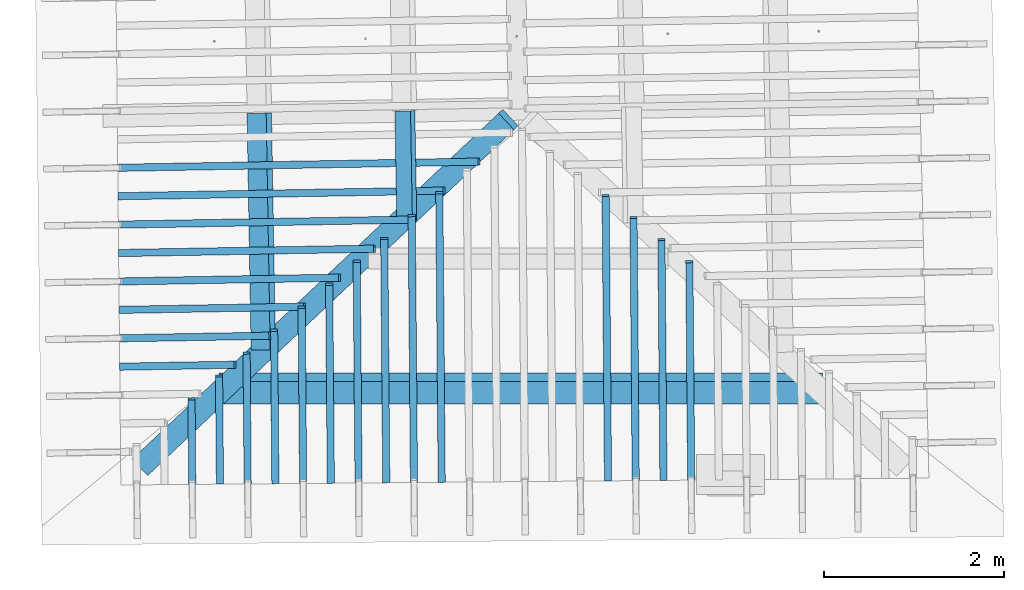
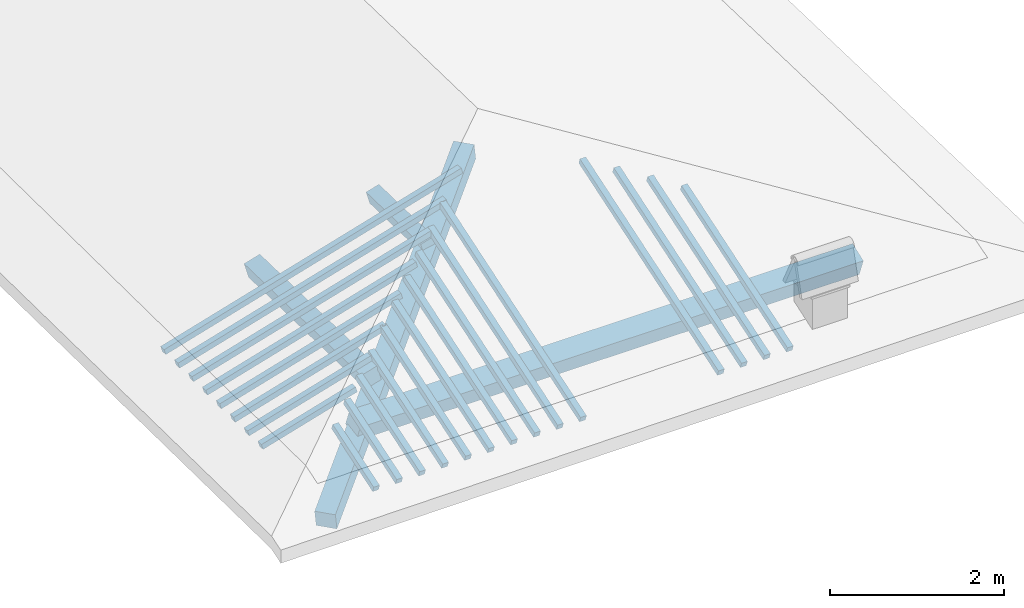
# One storey, part 1 of 19: 23 beams, 3 members, 2 elements without a shape of their own.
"""IFC4 building model written with IfcOpenShell, lengths in metres."""

from ifc_helpers import new_model, entity, si_unit, converted_unit, derived_unit, direction, frame, origin, place, context, subcontext, project, spatial, indexed_curve, outline, extrude, source, transform, mapped, material, type_object, type_shapes, element, aggregate, save


model = new_model("IFC4")

# Units and contexts
model_context = context("Model", 3, precision=1e-05, world=origin(), true_north=direction((6.123233995736766e-17, 1.0)))
body_context = subcontext(model_context, "Body", "Model", "MODEL_VIEW")
ifc_project = project(units=[si_unit("LENGTHUNIT", "METRE"), si_unit("AREAUNIT", "SQUARE_METRE"), si_unit("VOLUMEUNIT", "CUBIC_METRE"), converted_unit("PLANEANGLEUNIT", "DEGREE", entity("IfcPlaneAngleMeasure", 0.017453292519943278), si_unit("PLANEANGLEUNIT", "RADIAN"), dimensions=[0, 0, 0, 0, 0, 0, 0]), derived_unit("THERMALTRANSMITTANCEUNIT", [(si_unit("MASSUNIT", "GRAM", prefix="KILO"), 1), (si_unit("THERMODYNAMICTEMPERATUREUNIT", "KELVIN"), -1), (si_unit("TIMEUNIT", "SECOND"), -3)])], contexts=[model_context])

# Site, building, storey
site_placement = place(None, origin())
site = spatial("IfcSite", under=ifc_project, at=site_placement, CompositionType="ELEMENT")
building_placement = place(site_placement, origin())
building = spatial("IfcBuilding", under=site, at=building_placement, CompositionType="ELEMENT")
storey_placement = place(building_placement, frame((0.0, 0.0, 3.28)))
storey = spatial("IfcBuildingStorey", under=building, at=storey_placement, Name="Livello Copertura", CompositionType="ELEMENT", Elevation=3.28)

# Beam
ifc_material = material(Name="Legno - Legno da costruzione", Category="Legno")
beam_type_1 = type_object("IfcBeamType", Name="Legno:250x250", PredefinedType="BEAM", material=ifc_material)
shared_shape_1 = source(origin(), body_context, "Body", "SweptSolid", [
    extrude(outline(indexed_curve([(-2.8865, -0.12500000000000164), (2.8865, -0.12500000000000164), (2.8865, 0.12500000000000164), (-2.8865, 0.12500000000000164), (-2.8865, -0.12500000000000164)], self_intersect=False)), frame((-0.09300000000000051, 0.0, -0.1250000000000054), z_axis=(0.0, 0.0, 1.0), x_axis=(-1.0, 0.0, 0.0)), (0.0, 0.0, 1.0), 0.2499999999999999),
])
type_shapes(beam_type_1, [shared_shape_1])
beam_1_placement = place(storey_placement, frame((-2.1819750349168454, -1.0245673209281938, 0.3635737384132199), z_axis=(-0.1841295453761407, -0.1738218141454754, 0.967410092694278), x_axis=(0.7034691955432926, 0.6640883814436331, 0.2532147557968305)))
element("IfcBeam", 1, at=beam_1_placement, inside=storey, type_object=beam_type_1, material=ifc_material, Name="Legno:250x250", ObjectType="Legno:250x250", PredefinedType="BEAM", context=body_context, shape_type="MappedRepresentation", body=[
    mapped(shared_shape_1, transform((0.0, 0.0, 0.0), scale=1.0)),
])

# Members
member_type_1 = type_object("IfcMemberType", Name="Legno:220x220", PredefinedType="PURLIN", material=ifc_material)
shared_shape_2 = source(origin(), body_context, "Body", "SweptSolid", [
    extrude(outline(indexed_curve([(-0.11000000000000108, -0.11000000000000044), (0.11000000000000193, -0.11000000000000029), (0.110000000000002, 0.10999999999999963), (-0.11000000000000106, 0.10999999999999947), (-0.11000000000000108, -0.11000000000000044)], self_intersect=False)), frame((-2.9781171366202996, 0.89954546921723, 3.646958206215557), z_axis=(0.01708489701561066, -0.9998540424951864, 0.0), x_axis=(-0.9630219859926785, -0.016455533263029242, -0.2689198206152659)), (0.0, 0.0, 1.0), 2.6226681228820965),
])
type_shapes(member_type_1, [shared_shape_2])
member_1_placement = place(storey_placement, frame((0.0, 0.0, -3.28)))
element("IfcMember", 2, at=member_1_placement, inside=storey, type_object=member_type_1, material=ifc_material, Name="Legno:220x220", ObjectType="Legno:220x220", PredefinedType="PURLIN", context=body_context, shape_type="MappedRepresentation", body=[
    mapped(shared_shape_2, transform((0.0, 0.0, 0.0), scale=1.0)),
])
member_type_2 = type_object("IfcMemberType", Name="Legno:265x265", PredefinedType="PURLIN", material=ifc_material)
shared_shape_3 = source(origin(), body_context, "Body", "SweptSolid", [
    extrude(outline(indexed_curve([(-3.3463770603795675, -0.13250000000000164), (3.3463770603795675, -0.13250000000000164), (3.3463770603795675, 0.13250000000000164), (-3.3463770603795675, 0.13250000000000164), (-3.3463770603795675, -0.13250000000000164)], self_intersect=False)), frame((0.018176232400256256, 0.0, -0.13250000000000545), z_axis=(0.0, 0.0, 1.0), x_axis=(-1.0, 0.0, 0.0)), (0.0, 0.0, 1.0), 0.2649999999999999),
])
type_shapes(member_type_2, [shared_shape_3])
member_2_placement = place(storey_placement, frame((-0.0971509312741571, -2.151959629485876, 0.12418479170253889), z_axis=(0.0, -0.3542910379977155, 0.9351352096860119), x_axis=(1.0, 0.0, 0.0)))
element("IfcMember", 3, at=member_2_placement, inside=storey, type_object=member_type_2, material=ifc_material, Name="Legno:265x265", ObjectType="Legno:265x265", PredefinedType="PURLIN", context=body_context, shape_type="MappedRepresentation", body=[
    mapped(shared_shape_3, transform((0.0, 0.0, 0.0), scale=1.0)),
])
member_type_3 = type_object("IfcMemberType", Name="Legno:180x180", PredefinedType="PURLIN", material=ifc_material)
shared_shape_4 = source(origin(), body_context, "Body", "SweptSolid", [
    extrude(outline(indexed_curve([(-0.09000000000000193, -0.09000000000000048), (0.09000000000000151, -0.09000000000000055), (0.0900000000000019, 0.08999999999999937), (-0.09000000000000154, 0.08999999999999944), (-0.09000000000000193, -0.09000000000000048)], self_intersect=False)), frame((-1.3641247132135974, 0.9270290763723007, 4.0767390011549605), z_axis=(0.017084897015610844, -0.9998540424951865, 0.0), x_axis=(-0.9630219859926783, -0.016455533263029284, -0.2689198206152666)), (0.0, 0.0, 1.0), 1.2258736313036205),
])
type_shapes(member_type_3, [shared_shape_4])
member_3_placement = place(storey_placement, frame((0.0, 0.0, -3.28)))
element("IfcMember", 4, at=member_3_placement, inside=storey, type_object=member_type_3, material=ifc_material, Name="Legno:180x180", ObjectType="Legno:180x180", PredefinedType="PURLIN", context=body_context, shape_type="MappedRepresentation", body=[
    mapped(shared_shape_4, transform((0.0, 0.0, 0.0), scale=1.0)),
])

# Assembly, beams
assembly_1_placement = place(storey_placement, origin())
assembly_1 = element("IfcElementAssembly", 5, at=assembly_1_placement, inside=storey, Name="Sistema di travi strutturali:Sistema di travi strutturali", ObjectType="Sistema di travi strutturali:Sistema di travi strutturali", AssemblyPlace="NOTDEFINED", PredefinedType="BEAM_GRID")
beam_type_2 = type_object("IfcBeamType", Name="Legno:80x80", PredefinedType="JOIST", material=ifc_material)
shared_shape_5 = source(origin(), body_context, "Body", "SweptSolid", [
    extrude(outline(indexed_curve([(-2.0725000000000002, -0.04000000000000169), (2.0725000000000002, -0.04000000000000169), (2.0725000000000002, 0.04000000000000169), (-2.0725000000000002, 0.04000000000000169), (-2.0725000000000002, -0.04000000000000169)], self_intersect=False)), frame((0.0, 0.0, -0.040000000000005476), z_axis=(0.0, 0.0, 1.0), x_axis=(-1.0, 0.0, 0.0)), (0.0, 0.0, 1.0), 0.07999999999999997),
])
type_shapes(beam_type_2, [shared_shape_5])
beam_2_placement = place(assembly_1_placement, frame((-2.540443742400321, 0.3301116459614146, 0.6418508556695266), z_axis=(-0.26888056974925345, -0.004594467440668276, 0.9631625667976583), x_axis=(0.9630219859926786, 0.016455533263026963, 0.26891982061526537)))
beam_2 = element("IfcBeam", 6, at=beam_2_placement, type_object=beam_type_2, material=ifc_material, Name="Legno:80x80", ObjectType="Legno:80x80", PredefinedType="JOIST", context=body_context, shape_type="MappedRepresentation", body=[
    mapped(shared_shape_5, transform((0.0, 0.0, 0.0), scale=1.0)),
])
beam_type_3 = type_object("IfcBeamType", Name="Legno:80x80", PredefinedType="JOIST", material=ifc_material)
shared_shape_6 = source(origin(), body_context, "Body", "SweptSolid", [
    extrude(outline(indexed_curve([(-1.8705, -0.04000000000000169), (1.8705, -0.04000000000000169), (1.8705, 0.04000000000000169), (-1.8705, 0.04000000000000169), (-1.8705, -0.04000000000000169)], self_intersect=False)), frame((0.0, 0.0, -0.040000000000005476), z_axis=(0.0, 0.0, 1.0), x_axis=(-1.0, 0.0, 0.0)), (0.0, 0.0, 1.0), 0.07999999999999997),
])
type_shapes(beam_type_3, [shared_shape_6])
beam_3_placement = place(assembly_1_placement, frame((-2.732021318734577, 0.011792101672826176, 0.5868507980634393), z_axis=(-0.2688805697492534, -0.004594467440668275, 0.9631625667976583), x_axis=(0.9630219859926786, 0.01645553326302697, 0.2689198206152653)))
beam_3 = element("IfcBeam", 7, at=beam_3_placement, type_object=beam_type_3, material=ifc_material, Name="Legno:80x80", ObjectType="Legno:80x80", PredefinedType="JOIST", context=body_context, shape_type="MappedRepresentation", body=[
    mapped(shared_shape_6, transform((0.0, 0.0, 0.0), scale=1.0)),
])
beam_type_4 = type_object("IfcBeamType", Name="Legno:80x80", PredefinedType="JOIST", material=ifc_material)
shared_shape_7 = source(origin(), body_context, "Body", "SweptSolid", [
    extrude(outline(indexed_curve([(-1.6685, -0.04000000000000169), (1.6685, -0.04000000000000169), (1.6685, 0.04000000000000169), (-1.6685, 0.04000000000000169), (-1.6685, -0.04000000000000169)], self_intersect=False)), frame((0.0, 0.0, -0.040000000000005476), z_axis=(0.0, 0.0, 1.0), x_axis=(-1.0, 0.0, 0.0)), (0.0, 0.0, 1.0), 0.07999999999999997),
])
type_shapes(beam_type_4, [shared_shape_7])
beam_4_placement = place(assembly_1_placement, frame((-2.9235988950688316, -0.30652744261576, 0.5318507404573531), z_axis=(-0.2688805697492536, -0.004594467440668277, 0.9631625667976583), x_axis=(0.9630219859926786, 0.016455533263026952, 0.26891982061526554)))
beam_4 = element("IfcBeam", 8, at=beam_4_placement, type_object=beam_type_4, material=ifc_material, Name="Legno:80x80", ObjectType="Legno:80x80", PredefinedType="JOIST", context=body_context, shape_type="MappedRepresentation", body=[
    mapped(shared_shape_7, transform((0.0, 0.0, 0.0), scale=1.0)),
])
beam_type_5 = type_object("IfcBeamType", Name="Legno:80x80", PredefinedType="JOIST", material=ifc_material)
shared_shape_8 = source(origin(), body_context, "Body", "SweptSolid", [
    extrude(outline(indexed_curve([(-1.466, -0.04000000000000169), (1.466, -0.04000000000000169), (1.466, 0.04000000000000169), (-1.466, 0.04000000000000169), (-1.466, -0.04000000000000169)], self_intersect=False)), frame((0.0, 0.0, -0.040000000000005476), z_axis=(0.0, 0.0, 1.0), x_axis=(-1.0, 0.0, 0.0)), (0.0, 0.0, 1.0), 0.07999999999999997),
])
type_shapes(beam_type_5, [shared_shape_8])
beam_5_placement = place(assembly_1_placement, frame((-3.1151764714030876, -0.6248469869043484, 0.4768506828512653), z_axis=(-0.2688805697492535, -0.004594467440668277, 0.9631625667976582), x_axis=(0.9630219859926786, 0.016455533263026963, 0.2689198206152654)))
beam_5 = element("IfcBeam", 9, at=beam_5_placement, type_object=beam_type_5, material=ifc_material, Name="Legno:80x80", ObjectType="Legno:80x80", PredefinedType="JOIST", context=body_context, shape_type="MappedRepresentation", body=[
    mapped(shared_shape_8, transform((0.0, 0.0, 0.0), scale=1.0)),
])
beam_type_6 = type_object("IfcBeamType", Name="Legno:80x80", PredefinedType="JOIST", material=ifc_material)
shared_shape_9 = source(origin(), body_context, "Body", "SweptSolid", [
    extrude(outline(indexed_curve([(-1.2640000000000002, -0.04000000000000169), (1.2640000000000002, -0.04000000000000169), (1.2640000000000002, 0.04000000000000169), (-1.2640000000000002, 0.04000000000000169), (-1.2640000000000002, -0.04000000000000169)], self_intersect=False)), frame((0.0, 0.0, -0.040000000000005476), z_axis=(0.0, 0.0, 1.0), x_axis=(-1.0, 0.0, 0.0)), (0.0, 0.0, 1.0), 0.07999999999999997),
])
type_shapes(beam_type_6, [shared_shape_9])
beam_6_placement = place(assembly_1_placement, frame((-3.3067540477373427, -0.9431665311929367, 0.4218506252451776), z_axis=(-0.26888056974925345, -0.004594467440668276, 0.9631625667976582), x_axis=(0.9630219859926786, 0.016455533263026956, 0.26891982061526537)))
beam_6 = element("IfcBeam", 10, at=beam_6_placement, type_object=beam_type_6, material=ifc_material, Name="Legno:80x80", ObjectType="Legno:80x80", PredefinedType="JOIST", context=body_context, shape_type="MappedRepresentation", body=[
    mapped(shared_shape_9, transform((0.0, 0.0, 0.0), scale=1.0)),
])
beam_type_7 = type_object("IfcBeamType", Name="Legno:80x80", PredefinedType="JOIST", material=ifc_material)
shared_shape_10 = source(origin(), body_context, "Body", "SweptSolid", [
    extrude(outline(indexed_curve([(-1.062, -0.04000000000000169), (1.062, -0.04000000000000169), (1.062, 0.04000000000000169), (-1.062, 0.04000000000000169), (-1.062, -0.04000000000000169)], self_intersect=False)), frame((0.0, 0.0, -0.040000000000005476), z_axis=(0.0, 0.0, 1.0), x_axis=(-1.0, 0.0, 0.0)), (0.0, 0.0, 1.0), 0.07999999999999997),
])
type_shapes(beam_type_7, [shared_shape_10])
beam_7_placement = place(assembly_1_placement, frame((-3.4983316240715996, -1.2614860754815251, 0.36685056763908974), z_axis=(-0.2688805697492537, -0.00459446744066828, 0.9631625667976582), x_axis=(0.9630219859926786, 0.016455533263026956, 0.26891982061526565)))
beam_7 = element("IfcBeam", 11, at=beam_7_placement, type_object=beam_type_7, material=ifc_material, Name="Legno:80x80", ObjectType="Legno:80x80", PredefinedType="JOIST", context=body_context, shape_type="MappedRepresentation", body=[
    mapped(shared_shape_10, transform((0.0, 0.0, 0.0), scale=1.0)),
])
beam_type_8 = type_object("IfcBeamType", Name="Legno:80x80", PredefinedType="JOIST", material=ifc_material)
shared_shape_11 = source(origin(), body_context, "Body", "SweptSolid", [
    extrude(outline(indexed_curve([(-0.8595, -0.04000000000000169), (0.8595, -0.04000000000000169), (0.8595, 0.04000000000000169), (-0.8595, 0.04000000000000169), (-0.8595, -0.04000000000000169)], self_intersect=False)), frame((0.0, 0.0, -0.040000000000005476), z_axis=(0.0, 0.0, 1.0), x_axis=(-1.0, 0.0, 0.0)), (0.0, 0.0, 1.0), 0.07999999999999997),
])
type_shapes(beam_type_8, [shared_shape_11])
beam_8_placement = place(assembly_1_placement, frame((-3.6899092004058556, -1.5798056197701134, 0.3118505100330027), z_axis=(-0.2688805697492537, -0.00459446744066828, 0.9631625667976582), x_axis=(0.9630219859926786, 0.01645553326302695, 0.26891982061526565)))
beam_8 = element("IfcBeam", 12, at=beam_8_placement, type_object=beam_type_8, material=ifc_material, Name="Legno:80x80", ObjectType="Legno:80x80", PredefinedType="JOIST", context=body_context, shape_type="MappedRepresentation", body=[
    mapped(shared_shape_11, transform((0.0, 0.0, 0.0), scale=1.0)),
])
beam_type_9 = type_object("IfcBeamType", Name="Legno:80x80", PredefinedType="JOIST", material=ifc_material)
shared_shape_12 = source(origin(), body_context, "Body", "SweptSolid", [
    extrude(outline(indexed_curve([(-0.6575, -0.04000000000000169), (0.6575, -0.04000000000000169), (0.6575, 0.04000000000000169), (-0.6575, 0.04000000000000169), (-0.6575, -0.04000000000000169)], self_intersect=False)), frame((0.0, 0.0, -0.040000000000005476), z_axis=(0.0, 0.0, 1.0), x_axis=(-1.0, 0.0, 0.0)), (0.0, 0.0, 1.0), 0.07999999999999997),
])
type_shapes(beam_type_9, [shared_shape_12])
beam_9_placement = place(assembly_1_placement, frame((-3.8814867767401138, -1.8981251640587042, 0.2568504524269154), z_axis=(-0.2688805697492534, -0.004594467440668276, 0.9631625667976583), x_axis=(0.9630219859926787, 0.016455533263026963, 0.2689198206152653)))
beam_9 = element("IfcBeam", 13, at=beam_9_placement, type_object=beam_type_9, material=ifc_material, Name="Legno:80x80", ObjectType="Legno:80x80", PredefinedType="JOIST", context=body_context, shape_type="MappedRepresentation", body=[
    mapped(shared_shape_12, transform((0.0, 0.0, 0.0), scale=1.0)),
])
aggregate(assembly_1, [beam_2, beam_3, beam_4, beam_5, beam_6, beam_7, beam_8, beam_9])

assembly_2_placement = place(storey_placement, origin())
assembly_2 = element("IfcElementAssembly", 14, at=assembly_2_placement, inside=storey, Name="Sistema di travi strutturali:Sistema di travi strutturali", ObjectType="Sistema di travi strutturali:Sistema di travi strutturali", AssemblyPlace="NOTDEFINED", PredefinedType="BEAM_GRID")
beam_type_10 = type_object("IfcBeamType", Name="Legno:80x80", PredefinedType="JOIST", material=ifc_material)
shared_shape_13 = source(origin(), body_context, "Body", "SweptSolid", [
    extrude(outline(indexed_curve([(-1.2745, -0.04000000000000169), (1.2745, -0.04000000000000169), (1.2745, 0.04000000000000169), (-1.2745, 0.04000000000000169), (-1.2745, -0.04000000000000169)], self_intersect=False)), frame((0.0, 0.0, -0.040000000000005476), z_axis=(0.0, 0.0, 1.0), x_axis=(-1.0, 0.0, 0.0)), (0.0, 0.0, 1.0), 0.07999999999999997),
])
type_shapes(beam_type_10, [shared_shape_13])
beam_10_placement = place(assembly_2_placement, frame((1.799448701656348, -1.9488490470862634, 0.3907229973410812), z_axis=(0.0033933227624359896, -0.3255504700615085, 0.9455185755993168), x_axis=(-0.00793235019477952, 0.9454855083215804, 0.3255675527049189)))
beam_10 = element("IfcBeam", 15, at=beam_10_placement, type_object=beam_type_10, material=ifc_material, Name="Legno:80x80", ObjectType="Legno:80x80", PredefinedType="JOIST", context=body_context, shape_type="MappedRepresentation", body=[
    mapped(shared_shape_13, transform((0.0, 0.0, 0.0), scale=1.0)),
])
beam_type_11 = type_object("IfcBeamType", Name="Legno:80x80", PredefinedType="JOIST", material=ifc_material)
shared_shape_14 = source(origin(), body_context, "Body", "SweptSolid", [
    extrude(outline(indexed_curve([(-1.405, -0.04000000000000169), (1.405, -0.04000000000000169), (1.405, 0.04000000000000169), (-1.405, 0.04000000000000169), (-1.405, -0.04000000000000169)], self_intersect=False)), frame((0.0, 0.0, -0.040000000000005476), z_axis=(0.0, 0.0, 1.0), x_axis=(-1.0, 0.0, 0.0)), (0.0, 0.0, 1.0), 0.07999999999999997),
])
type_shapes(beam_type_11, [shared_shape_14])
beam_11_placement = place(assembly_2_placement, frame((1.4911245811311307, -1.8280614472713421, 0.43341777266915715), z_axis=(0.0033933227624359887, -0.3255504700615087, 0.9455185755993166), x_axis=(-0.007932350194779557, 0.9454855083215804, 0.325567552704919)))
beam_11 = element("IfcBeam", 16, at=beam_11_placement, type_object=beam_type_11, material=ifc_material, Name="Legno:80x80", ObjectType="Legno:80x80", PredefinedType="JOIST", context=body_context, shape_type="MappedRepresentation", body=[
    mapped(shared_shape_14, transform((0.0, 0.0, 0.0), scale=1.0)),
])
beam_type_12 = type_object("IfcBeamType", Name="Legno:80x80", PredefinedType="JOIST", material=ifc_material)
shared_shape_15 = source(origin(), body_context, "Body", "SweptSolid", [
    extrude(outline(indexed_curve([(-1.5355, -0.04000000000000169), (1.5355, -0.04000000000000169), (1.5355, 0.04000000000000169), (-1.5355, 0.04000000000000169), (-1.5355, -0.04000000000000169)], self_intersect=False)), frame((0.0, 0.0, -0.040000000000005476), z_axis=(0.0, 0.0, 1.0), x_axis=(-1.0, 0.0, 0.0)), (0.0, 0.0, 1.0), 0.07999999999999997),
])
type_shapes(beam_type_12, [shared_shape_15])
beam_12_placement = place(assembly_2_placement, frame((1.1828004606059142, -1.7072738474564202, 0.4761125479972341), z_axis=(0.003393322762435989, -0.32555047006150856, 0.9455185755993168), x_axis=(-0.007932350194779537, 0.9454855083215804, 0.32556755270491894)))
beam_12 = element("IfcBeam", 17, at=beam_12_placement, type_object=beam_type_12, material=ifc_material, Name="Legno:80x80", ObjectType="Legno:80x80", PredefinedType="JOIST", context=body_context, shape_type="MappedRepresentation", body=[
    mapped(shared_shape_15, transform((0.0, 0.0, 0.0), scale=1.0)),
])
beam_type_13 = type_object("IfcBeamType", Name="Legno:80x80", PredefinedType="JOIST", material=ifc_material)
shared_shape_16 = source(origin(), body_context, "Body", "SweptSolid", [
    extrude(outline(indexed_curve([(-1.666, -0.04000000000000169), (1.666, -0.04000000000000169), (1.666, 0.04000000000000169), (-1.666, 0.04000000000000169), (-1.666, -0.04000000000000169)], self_intersect=False)), frame((0.0, 0.0, -0.040000000000005476), z_axis=(0.0, 0.0, 1.0), x_axis=(-1.0, 0.0, 0.0)), (0.0, 0.0, 1.0), 0.07999999999999997),
])
type_shapes(beam_type_13, [shared_shape_16])
beam_13_placement = place(assembly_2_placement, frame((0.8744763400806965, -1.5864862476414978, 0.5188073233253101), z_axis=(0.00339332276243599, -0.3255504700615087, 0.9455185755993166), x_axis=(-0.007932350194779563, 0.9454855083215803, 0.32556755270491905)))
beam_13 = element("IfcBeam", 18, at=beam_13_placement, type_object=beam_type_13, material=ifc_material, Name="Legno:80x80", ObjectType="Legno:80x80", PredefinedType="JOIST", context=body_context, shape_type="MappedRepresentation", body=[
    mapped(shared_shape_16, transform((0.0, 0.0, 0.0), scale=1.0)),
])
beam_type_14 = type_object("IfcBeamType", Name="Legno:80x80", PredefinedType="JOIST", material=ifc_material)
shared_shape_17 = source(origin(), body_context, "Body", "SweptSolid", [
    extrude(outline(indexed_curve([(-1.691, -0.04000000000000169), (1.691, -0.04000000000000169), (1.691, 0.04000000000000169), (-1.691, 0.04000000000000169), (-1.691, -0.04000000000000169)], self_intersect=False)), frame((0.0, 0.0, -0.040000000000005476), z_axis=(0.0, 0.0, 1.0), x_axis=(-1.0, 0.0, 0.0)), (0.0, 0.0, 1.0), 0.07999999999999997),
])
type_shapes(beam_type_14, [shared_shape_17])
beam_14_placement = place(assembly_2_placement, frame((-0.9694559132154893, -1.5784086758363005, 0.5282060964588845), z_axis=(0.00339332276243599, -0.3255504700615086, 0.9455185755993168), x_axis=(-0.00793235019477954, 0.9454855083215803, 0.325567552704919)))
beam_14 = element("IfcBeam", 19, at=beam_14_placement, type_object=beam_type_14, material=ifc_material, Name="Legno:80x80", ObjectType="Legno:80x80", PredefinedType="JOIST", context=body_context, shape_type="MappedRepresentation", body=[
    mapped(shared_shape_17, transform((0.0, 0.0, 0.0), scale=1.0)),
])
beam_type_15 = type_object("IfcBeamType", Name="Legno:80x80", PredefinedType="JOIST", material=ifc_material)
shared_shape_18 = source(origin(), body_context, "Body", "SweptSolid", [
    extrude(outline(indexed_curve([(-1.5579999999999998, -0.04000000000000169), (1.5579999999999998, -0.04000000000000169), (1.5579999999999998, 0.04000000000000169), (-1.5579999999999998, 0.04000000000000169), (-1.5579999999999998, -0.04000000000000169)], self_intersect=False)), frame((0.0, 0.0, -0.040000000000005476), z_axis=(0.0, 0.0, 1.0), x_axis=(-1.0, 0.0, 0.0)), (0.0, 0.0, 1.0), 0.07999999999999997),
])
type_shapes(beam_type_15, [shared_shape_18])
beam_15_placement = place(assembly_2_placement, frame((-1.2756894898037632, -1.7068005686503949, 0.4850986496635409), z_axis=(0.0033933227624359896, -0.32555047006150856, 0.9455185755993168), x_axis=(-0.007932350194779546, 0.9454855083215804, 0.32556755270491894)))
beam_15 = element("IfcBeam", 20, at=beam_15_placement, type_object=beam_type_15, material=ifc_material, Name="Legno:80x80", ObjectType="Legno:80x80", PredefinedType="JOIST", context=body_context, shape_type="MappedRepresentation", body=[
    mapped(shared_shape_18, transform((0.0, 0.0, 0.0), scale=1.0)),
])
beam_type_16 = type_object("IfcBeamType", Name="Legno:80x80", PredefinedType="JOIST", material=ifc_material)
shared_shape_19 = source(origin(), body_context, "Body", "SweptSolid", [
    extrude(outline(indexed_curve([(-1.425, -0.04000000000000169), (1.425, -0.04000000000000169), (1.425, 0.04000000000000169), (-1.425, 0.04000000000000169), (-1.425, -0.04000000000000169)], self_intersect=False)), frame((0.0, 0.0, -0.040000000000005476), z_axis=(0.0, 0.0, 1.0), x_axis=(-1.0, 0.0, 0.0)), (0.0, 0.0, 1.0), 0.07999999999999997),
])
type_shapes(beam_type_16, [shared_shape_19])
beam_16_placement = place(assembly_2_placement, frame((-1.5819230663920358, -1.835192461464489, 0.4419912028681974), z_axis=(0.0033933227624359883, -0.3255504700615085, 0.9455185755993168), x_axis=(-0.007932350194779557, 0.9454855083215804, 0.3255675527049189)))
beam_16 = element("IfcBeam", 21, at=beam_16_placement, type_object=beam_type_16, material=ifc_material, Name="Legno:80x80", ObjectType="Legno:80x80", PredefinedType="JOIST", context=body_context, shape_type="MappedRepresentation", body=[
    mapped(shared_shape_19, transform((0.0, 0.0, 0.0), scale=1.0)),
])
beam_type_17 = type_object("IfcBeamType", Name="Legno:80x80", PredefinedType="JOIST", material=ifc_material)
shared_shape_20 = source(origin(), body_context, "Body", "SweptSolid", [
    extrude(outline(indexed_curve([(-1.2925, -0.04000000000000169), (1.2925, -0.04000000000000169), (1.2925, 0.04000000000000169), (-1.2925, 0.04000000000000169), (-1.2925, -0.04000000000000169)], self_intersect=False)), frame((0.0, 0.0, -0.040000000000005476), z_axis=(0.0, 0.0, 1.0), x_axis=(-1.0, 0.0, 0.0)), (0.0, 0.0, 1.0), 0.07999999999999997),
])
type_shapes(beam_type_17, [shared_shape_20])
beam_17_placement = place(assembly_2_placement, frame((-1.8881566429803072, -1.9635843542785834, 0.3988837560728542), z_axis=(0.003393322762435988, -0.3255504700615085, 0.9455185755993168), x_axis=(-0.007932350194779567, 0.9454855083215805, 0.32556755270491883)))
beam_17 = element("IfcBeam", 22, at=beam_17_placement, type_object=beam_type_17, material=ifc_material, Name="Legno:80x80", ObjectType="Legno:80x80", PredefinedType="JOIST", context=body_context, shape_type="MappedRepresentation", body=[
    mapped(shared_shape_20, transform((0.0, 0.0, 0.0), scale=1.0)),
])
beam_type_18 = type_object("IfcBeamType", Name="Legno:80x80", PredefinedType="JOIST", material=ifc_material)
shared_shape_21 = source(origin(), body_context, "Body", "SweptSolid", [
    extrude(outline(indexed_curve([(-1.1595000000000002, -0.04000000000000169), (1.1595000000000002, -0.04000000000000169), (1.1595000000000002, 0.04000000000000169), (-1.1595000000000002, 0.04000000000000169), (-1.1595000000000002, -0.04000000000000169)], self_intersect=False)), frame((0.0, 0.0, -0.040000000000005476), z_axis=(0.0, 0.0, 1.0), x_axis=(-1.0, 0.0, 0.0)), (0.0, 0.0, 1.0), 0.07999999999999997),
])
type_shapes(beam_type_18, [shared_shape_21])
beam_18_placement = place(assembly_2_placement, frame((-2.1943902195685787, -2.0919762470926773, 0.35577630927751247), z_axis=(0.0033933227624359896, -0.32555047006150856, 0.9455185755993168), x_axis=(-0.007932350194779576, 0.9454855083215804, 0.32556755270491894)))
beam_18 = element("IfcBeam", 23, at=beam_18_placement, type_object=beam_type_18, material=ifc_material, Name="Legno:80x80", ObjectType="Legno:80x80", PredefinedType="JOIST", context=body_context, shape_type="MappedRepresentation", body=[
    mapped(shared_shape_21, transform((0.0, 0.0, 0.0), scale=1.0)),
])
beam_type_19 = type_object("IfcBeamType", Name="Legno:80x80", PredefinedType="JOIST", material=ifc_material)
shared_shape_22 = source(origin(), body_context, "Body", "SweptSolid", [
    extrude(outline(indexed_curve([(-1.0265, -0.04000000000000169), (1.0265, -0.04000000000000169), (1.0265, 0.04000000000000169), (-1.0265, 0.04000000000000169), (-1.0265, -0.04000000000000169)], self_intersect=False)), frame((0.0, 0.0, -0.040000000000005476), z_axis=(0.0, 0.0, 1.0), x_axis=(-1.0, 0.0, 0.0)), (0.0, 0.0, 1.0), 0.07999999999999997),
])
type_shapes(beam_type_19, [shared_shape_22])
beam_19_placement = place(assembly_2_placement, frame((-2.500623796156851, -2.220368139906772, 0.3126688624821684), z_axis=(0.0033933227624359883, -0.3255504700615085, 0.9455185755993167), x_axis=(-0.007932350194779463, 0.9454855083215804, 0.32556755270491883)))
beam_19 = element("IfcBeam", 24, at=beam_19_placement, type_object=beam_type_19, material=ifc_material, Name="Legno:80x80", ObjectType="Legno:80x80", PredefinedType="JOIST", context=body_context, shape_type="MappedRepresentation", body=[
    mapped(shared_shape_22, transform((0.0, 0.0, 0.0), scale=1.0)),
])
beam_type_20 = type_object("IfcBeamType", Name="Legno:80x80", PredefinedType="JOIST", material=ifc_material)
shared_shape_23 = source(origin(), body_context, "Body", "SweptSolid", [
    extrude(outline(indexed_curve([(-0.8935000000000001, -0.04000000000000169), (0.8935000000000001, -0.04000000000000169), (0.8935000000000001, 0.04000000000000169), (-0.8935000000000001, 0.04000000000000169), (-0.8935000000000001, -0.04000000000000169)], self_intersect=False)), frame((0.0, 0.0, -0.040000000000005476), z_axis=(0.0, 0.0, 1.0), x_axis=(-1.0, 0.0, 0.0)), (0.0, 0.0, 1.0), 0.07999999999999997),
])
type_shapes(beam_type_20, [shared_shape_23])
beam_20_placement = place(assembly_2_placement, frame((-2.8068573727451227, -2.3487600327208664, 0.2695614156868251), z_axis=(0.003393322762435991, -0.3255504700615088, 0.9455185755993166), x_axis=(-0.007932350194779622, 0.9454855083215803, 0.3255675527049191)))
beam_20 = element("IfcBeam", 25, at=beam_20_placement, type_object=beam_type_20, material=ifc_material, Name="Legno:80x80", ObjectType="Legno:80x80", PredefinedType="JOIST", context=body_context, shape_type="MappedRepresentation", body=[
    mapped(shared_shape_23, transform((0.0, 0.0, 0.0), scale=1.0)),
])
beam_type_21 = type_object("IfcBeamType", Name="Legno:80x80", PredefinedType="JOIST", material=ifc_material)
shared_shape_24 = source(origin(), body_context, "Body", "SweptSolid", [
    extrude(outline(indexed_curve([(-0.7605, -0.04000000000000169), (0.7605, -0.04000000000000169), (0.7605, 0.04000000000000169), (-0.7605, 0.04000000000000169), (-0.7605, -0.04000000000000169)], self_intersect=False)), frame((0.0, 0.0, -0.040000000000005476), z_axis=(0.0, 0.0, 1.0), x_axis=(-1.0, 0.0, 0.0)), (0.0, 0.0, 1.0), 0.07999999999999997),
])
type_shapes(beam_type_21, [shared_shape_24])
beam_21_placement = place(assembly_2_placement, frame((-3.1130909493333956, -2.4771519255349594, 0.22645396889148295), z_axis=(0.00339332276243599, -0.3255504700615086, 0.9455185755993168), x_axis=(-0.007932350194779461, 0.9454855083215803, 0.325567552704919)))
beam_21 = element("IfcBeam", 26, at=beam_21_placement, type_object=beam_type_21, material=ifc_material, Name="Legno:80x80", ObjectType="Legno:80x80", PredefinedType="JOIST", context=body_context, shape_type="MappedRepresentation", body=[
    mapped(shared_shape_24, transform((0.0, 0.0, 0.0), scale=1.0)),
])
beam_type_22 = type_object("IfcBeamType", Name="Legno:80x80", PredefinedType="JOIST", material=ifc_material)
shared_shape_25 = source(origin(), body_context, "Body", "SweptSolid", [
    extrude(outline(indexed_curve([(-0.6275000000000001, -0.04000000000000169), (0.6275000000000001, -0.04000000000000169), (0.6275000000000001, 0.04000000000000169), (-0.6275000000000001, 0.04000000000000169), (-0.6275000000000001, -0.04000000000000169)], self_intersect=False)), frame((0.0, 0.0, -0.040000000000005476), z_axis=(0.0, 0.0, 1.0), x_axis=(-1.0, 0.0, 0.0)), (0.0, 0.0, 1.0), 0.07999999999999997),
])
type_shapes(beam_type_22, [shared_shape_25])
beam_22_placement = place(assembly_2_placement, frame((-3.4193245259216676, -2.6055438183490542, 0.18334652209613922), z_axis=(0.0033933227624359926, -0.32555047006150906, 0.9455185755993165), x_axis=(-0.007932350194779688, 0.9454855083215802, 0.3255675527049194)))
beam_22 = element("IfcBeam", 27, at=beam_22_placement, type_object=beam_type_22, material=ifc_material, Name="Legno:80x80", ObjectType="Legno:80x80", PredefinedType="JOIST", context=body_context, shape_type="MappedRepresentation", body=[
    mapped(shared_shape_25, transform((0.0, 0.0, 0.0), scale=1.0)),
])
beam_type_23 = type_object("IfcBeamType", Name="Legno:80x80", PredefinedType="JOIST", material=ifc_material)
shared_shape_26 = source(origin(), body_context, "Body", "SweptSolid", [
    extrude(outline(indexed_curve([(-0.4945, -0.04000000000000169), (0.4945, -0.04000000000000169), (0.4945, 0.04000000000000169), (-0.4945, 0.04000000000000169), (-0.4945, -0.04000000000000169)], self_intersect=False)), frame((0.0, 0.0, -0.040000000000005476), z_axis=(0.0, 0.0, 1.0), x_axis=(-1.0, 0.0, 0.0)), (0.0, 0.0, 1.0), 0.07999999999999997),
])
type_shapes(beam_type_23, [shared_shape_26])
beam_23_placement = place(assembly_2_placement, frame((-3.72555810250994, -2.7339357111631495, 0.14023907530079616), z_axis=(0.0033933227624359874, -0.3255504700615084, 0.9455185755993168), x_axis=(-0.007932350194779472, 0.9454855083215804, 0.3255675527049188)))
beam_23 = element("IfcBeam", 28, at=beam_23_placement, type_object=beam_type_23, material=ifc_material, Name="Legno:80x80", ObjectType="Legno:80x80", PredefinedType="JOIST", context=body_context, shape_type="MappedRepresentation", body=[
    mapped(shared_shape_26, transform((0.0, 0.0, 0.0), scale=1.0)),
])
aggregate(assembly_2, [beam_10, beam_11, beam_12, beam_13, beam_14, beam_15, beam_16, beam_17, beam_18, beam_19, beam_20, beam_21, beam_22, beam_23])

save(model, "model.ifc")
